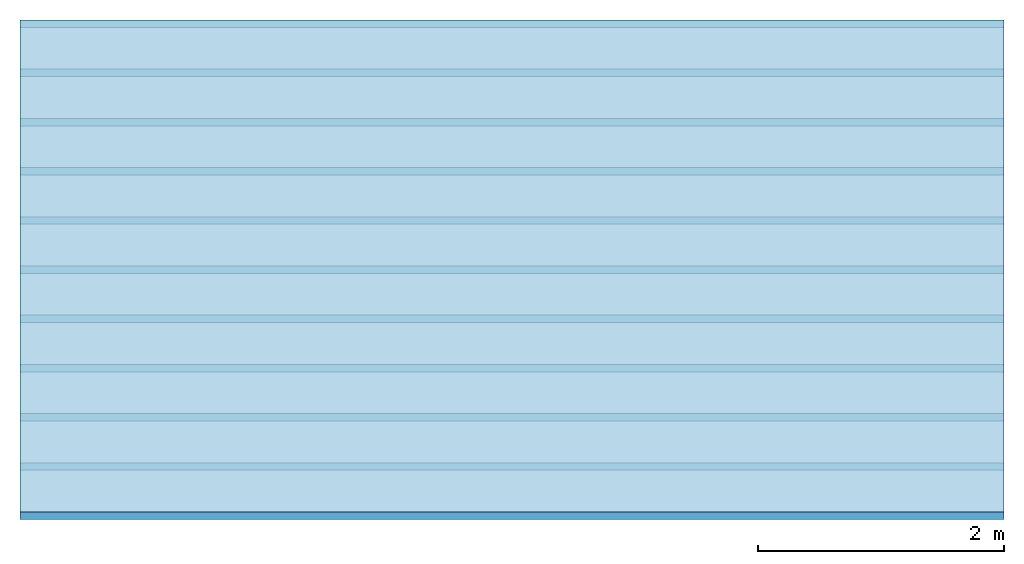
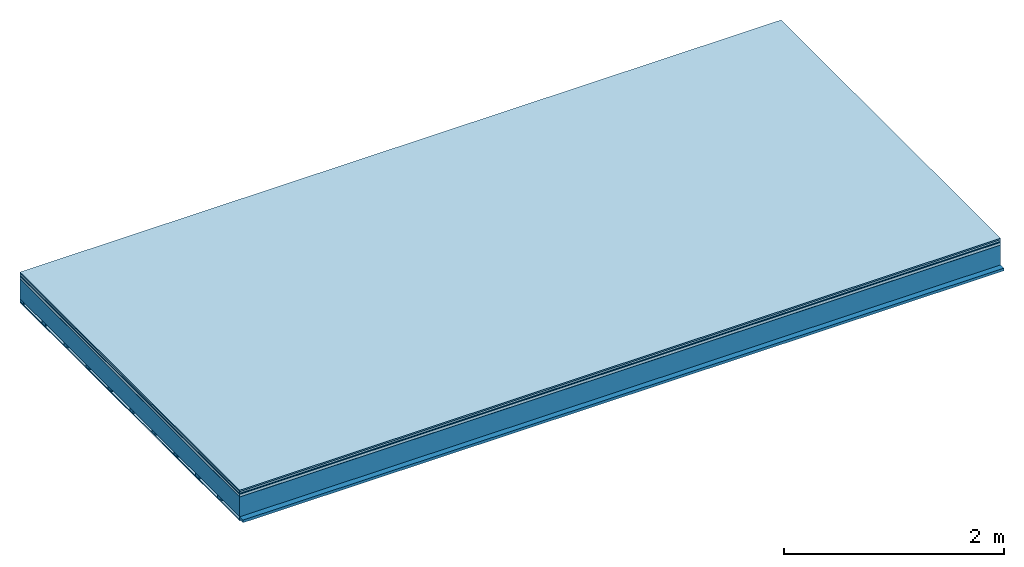
# One storey: 7 plates, 2 members, 1 element without a shape of its own.
"""IFC4 building model written with IfcOpenShell, lengths in metres."""

from ifc_helpers import new_model, si_unit, derived_unit, direction, frame, frame_2d, origin, origin_with_axes, place, context, project, spatial, rectangle, extrude, material, layer, layer_set, type_object, element, aggregate, save


model = new_model("IFC4")

# Units and contexts
plan_context = context("Plan", 3, precision=1e-05, world=origin(), true_north=direction((0.0, 1.0)))
model_context = context("Model", 3, precision=1e-05, world=origin(), true_north=direction((0.0, 1.0)))
ifc_project = project(units=[si_unit("LENGTHUNIT", "METRE"), derived_unit("SOUNDPRESSUREUNIT", [(si_unit("PRESSUREUNIT", "PASCAL", prefix="MICRO"), 0)]), si_unit("ENERGYUNIT", "JOULE", prefix="MEGA"), si_unit("MASSUNIT", "GRAM", prefix="KILO"), derived_unit("THERMALTRANSMITTANCEUNIT", [(si_unit("POWERUNIT", "WATT"), 1), (si_unit("AREAUNIT", "SQUARE_METRE"), -1), (si_unit("THERMODYNAMICTEMPERATUREUNIT", "KELVIN"), -1)]), derived_unit("AREADENSITYUNIT", [(si_unit("MASSUNIT", "GRAM", prefix="KILO"), 1), (si_unit("AREAUNIT", "SQUARE_METRE"), -1)]), derived_unit("USERDEFINED", [(si_unit("ENERGYUNIT", "JOULE", prefix="MEGA"), 1), (si_unit("AREAUNIT", "SQUARE_METRE"), -1)])], contexts=[plan_context, model_context])

# Site, building, storey
site = spatial("IfcSite", under=ifc_project)
building_placement = place(None, origin())
building = spatial("IfcBuilding", under=site, at=building_placement)
storey_placement = place(building_placement, origin())
storey = spatial("IfcBuildingStorey", under=building, at=storey_placement)

# Slab, members, plates
ifc_material_1 = material(Category="11.013")
ifc_layer_1 = layer(ifc_material_1, 0.015, Name="Flooring")
ifc_material_2 = material(Category="03.007")
ifc_layer_2 = layer(ifc_material_2, 0.02, Name="On-material")
ifc_material_3 = material(Name="Wood fiber generic product", Category="10.009")
ifc_layer_3 = layer(ifc_material_3, 0.01, Name="Impact sound insulation")
ifc_material_4 = material(Name="with broken")
ifc_layer_4 = layer(ifc_material_4, 0.03, Name="on Supporting structure")
ifc_material_5 = material(Name="protection", Category="09.007")
ifc_layer_5 = layer(ifc_material_5, 0.0005, Name="Sub-floor")
ifc_material_6 = material(Name="no composite action")
ifc_layer_6 = layer(ifc_material_6, 0.0, Name="Bond")
ifc_layer_7 = layer(None, 0.22, Name="Supporting structure")
ifc_material_7 = material(Name="of the art")
ifc_layer_8 = layer(ifc_material_7, 0.0, Name="Bond")
ifc_layer_9 = layer(None, 0.03, Name="Battens / profiles")
ifc_material_8 = material(Name="Plasterboard type A", Category="03.008")
ifc_layer_10 = layer(ifc_material_8, 0.0125, Name="Ceiling covering 1st layer")
ifc_material_9 = material(Category="04.001")
ifc_layer_11 = layer(ifc_material_9, 0.003, Name="Surface / treatment")
ifc_layer_set = layer_set([ifc_layer_1, ifc_layer_2, ifc_layer_3, ifc_layer_4, ifc_layer_5, ifc_layer_6, ifc_layer_7, ifc_layer_8, ifc_layer_9, ifc_layer_10, ifc_layer_11])
slab_type = type_object("IfcSlabType", Name="A2110", PredefinedType="NOTDEFINED", material=ifc_layer_set)
slab_placement = place(None, frame((0.0, 0.0, 0.0), z_axis=(0.0, 0.0, -1.0), x_axis=(1.0, 0.0, 0.0)))
slab = element("IfcSlab", 1, at=slab_placement, inside=storey, type_object=slab_type, material=ifc_layer_set, Name="Slab #1")
ifc_material_10 = material(Name="Solid timber panel")
member_1_placement = place(slab_placement, origin())
member_1 = element("IfcMember", 2, at=member_1_placement, material=ifc_material_10, Name="Supporting structure", context=plan_context, shape_type="SweptSolid", body=[
    extrude(rectangle(XDim=1.0, YDim=0.22, at=frame_2d((0.5, 0.11), x_axis=(1.0, 0.0))), frame((0.0, 4.0, 0.0755), z_axis=(0.0, -1.0, 0.0), x_axis=(1.0, 0.0, 0.0)), (0.0, 0.0, 1.0), 4.0),
    extrude(rectangle(XDim=1.0, YDim=0.22, at=frame_2d((0.5, 0.11), x_axis=(1.0, 0.0))), frame((1.0, 4.0, 0.0755), z_axis=(0.0, -1.0, 0.0), x_axis=(1.0, 0.0, 0.0)), (0.0, 0.0, 1.0), 4.0),
    extrude(rectangle(XDim=1.0, YDim=0.22, at=frame_2d((0.5, 0.11), x_axis=(1.0, 0.0))), frame((2.0, 4.0, 0.0755), z_axis=(0.0, -1.0, 0.0), x_axis=(1.0, 0.0, 0.0)), (0.0, 0.0, 1.0), 4.0),
    extrude(rectangle(XDim=1.0, YDim=0.22, at=frame_2d((0.5, 0.11), x_axis=(1.0, 0.0))), frame((3.0, 4.0, 0.0755), z_axis=(0.0, -1.0, 0.0), x_axis=(1.0, 0.0, 0.0)), (0.0, 0.0, 1.0), 4.0),
    extrude(rectangle(XDim=1.0, YDim=0.22, at=frame_2d((0.5, 0.11), x_axis=(1.0, 0.0))), frame((4.0, 4.0, 0.0755), z_axis=(0.0, -1.0, 0.0), x_axis=(1.0, 0.0, 0.0)), (0.0, 0.0, 1.0), 4.0),
    extrude(rectangle(XDim=1.0, YDim=0.22, at=frame_2d((0.5, 0.11), x_axis=(1.0, 0.0))), frame((5.0, 4.0, 0.0755), z_axis=(0.0, -1.0, 0.0), x_axis=(1.0, 0.0, 0.0)), (0.0, 0.0, 1.0), 4.0),
    extrude(rectangle(XDim=1.0, YDim=0.22, at=frame_2d((0.5, 0.11), x_axis=(1.0, 0.0))), frame((6.0, 4.0, 0.0755), z_axis=(0.0, -1.0, 0.0), x_axis=(1.0, 0.0, 0.0)), (0.0, 0.0, 1.0), 4.0),
    extrude(rectangle(XDim=1.0, YDim=0.22, at=frame_2d((0.5, 0.11), x_axis=(1.0, 0.0))), frame((7.0, 4.0, 0.0755), z_axis=(0.0, -1.0, 0.0), x_axis=(1.0, 0.0, 0.0)), (0.0, 0.0, 1.0), 4.0),
])
ifc_material_11 = material()
member_2_placement = place(slab_placement, origin())
member_2 = element("IfcMember", 3, at=member_2_placement, material=ifc_material_11, Name="Battens / profiles", context=plan_context, shape_type="SweptSolid", body=[
    extrude(rectangle(XDim=0.06, YDim=0.03, at=frame_2d((0.03, 0.015), x_axis=(1.0, 0.0))), frame((0.0, 0.0, 0.2955), z_axis=(1.0, 0.0, 0.0), x_axis=(0.0, 1.0, 0.0)), (0.0, 0.0, 1.0), 8.0),
    extrude(rectangle(XDim=0.06, YDim=0.03, at=frame_2d((0.03, 0.015), x_axis=(1.0, 0.0))), frame((0.0, 0.4, 0.2955), z_axis=(1.0, 0.0, 0.0), x_axis=(0.0, 1.0, 0.0)), (0.0, 0.0, 1.0), 8.0),
    extrude(rectangle(XDim=0.06, YDim=0.03, at=frame_2d((0.03, 0.015), x_axis=(1.0, 0.0))), frame((0.0, 0.8, 0.2955), z_axis=(1.0, 0.0, 0.0), x_axis=(0.0, 1.0, 0.0)), (0.0, 0.0, 1.0), 8.0),
    extrude(rectangle(XDim=0.06, YDim=0.03, at=frame_2d((0.03, 0.015), x_axis=(1.0, 0.0))), frame((0.0, 1.2, 0.2955), z_axis=(1.0, 0.0, 0.0), x_axis=(0.0, 1.0, 0.0)), (0.0, 0.0, 1.0), 8.0),
    extrude(rectangle(XDim=0.06, YDim=0.03, at=frame_2d((0.03, 0.015), x_axis=(1.0, 0.0))), frame((0.0, 1.6, 0.2955), z_axis=(1.0, 0.0, 0.0), x_axis=(0.0, 1.0, 0.0)), (0.0, 0.0, 1.0), 8.0),
    extrude(rectangle(XDim=0.06, YDim=0.03, at=frame_2d((0.03, 0.015), x_axis=(1.0, 0.0))), frame((0.0, 2.0, 0.2955), z_axis=(1.0, 0.0, 0.0), x_axis=(0.0, 1.0, 0.0)), (0.0, 0.0, 1.0), 8.0),
    extrude(rectangle(XDim=0.06, YDim=0.03, at=frame_2d((0.03, 0.015), x_axis=(1.0, 0.0))), frame((0.0, 2.4, 0.2955), z_axis=(1.0, 0.0, 0.0), x_axis=(0.0, 1.0, 0.0)), (0.0, 0.0, 1.0), 8.0),
    extrude(rectangle(XDim=0.06, YDim=0.03, at=frame_2d((0.03, 0.015), x_axis=(1.0, 0.0))), frame((0.0, 2.8, 0.2955), z_axis=(1.0, 0.0, 0.0), x_axis=(0.0, 1.0, 0.0)), (0.0, 0.0, 1.0), 8.0),
    extrude(rectangle(XDim=0.06, YDim=0.03, at=frame_2d((0.03, 0.015), x_axis=(1.0, 0.0))), frame((0.0, 3.2, 0.2955), z_axis=(1.0, 0.0, 0.0), x_axis=(0.0, 1.0, 0.0)), (0.0, 0.0, 1.0), 8.0),
    extrude(rectangle(XDim=0.06, YDim=0.03, at=frame_2d((0.03, 0.015), x_axis=(1.0, 0.0))), frame((0.0, 3.6, 0.2955), z_axis=(1.0, 0.0, 0.0), x_axis=(0.0, 1.0, 0.0)), (0.0, 0.0, 1.0), 8.0),
    extrude(rectangle(XDim=0.06, YDim=0.03, at=frame_2d((0.03, 0.015), x_axis=(1.0, 0.0))), frame((0.0, 4.0, 0.2955), z_axis=(1.0, 0.0, 0.0), x_axis=(0.0, 1.0, 0.0)), (0.0, 0.0, 1.0), 8.0),
])
plate_1_placement = place(slab_placement, origin())
plate_1 = element("IfcPlate", 4, at=plate_1_placement, material=ifc_material_1, Name="Flooring", context=plan_context, shape_type="SweptSolid", body=[
    extrude(rectangle(XDim=8.0, YDim=4.0, at=frame_2d((4.0, 2.0), x_axis=(1.0, 0.0))), origin_with_axes(), (0.0, 0.0, 1.0), 0.015),
])
plate_2_placement = place(slab_placement, origin())
plate_2 = element("IfcPlate", 5, at=plate_2_placement, material=ifc_material_2, Name="On-material", context=plan_context, shape_type="SweptSolid", body=[
    extrude(rectangle(XDim=8.0, YDim=4.0, at=frame_2d((4.0, 2.0), x_axis=(1.0, 0.0))), frame((0.0, 0.0, 0.015), z_axis=(0.0, 0.0, 1.0), x_axis=(1.0, 0.0, 0.0)), (0.0, 0.0, 1.0), 0.02),
])
plate_3_placement = place(slab_placement, origin())
plate_3 = element("IfcPlate", 6, at=plate_3_placement, material=ifc_material_3, Name="Impact sound insulation", context=plan_context, shape_type="SweptSolid", body=[
    extrude(rectangle(XDim=8.0, YDim=4.0, at=frame_2d((4.0, 2.0), x_axis=(1.0, 0.0))), frame((0.0, 0.0, 0.035), z_axis=(0.0, 0.0, 1.0), x_axis=(1.0, 0.0, 0.0)), (0.0, 0.0, 1.0), 0.01),
])
plate_4_placement = place(slab_placement, origin())
plate_4 = element("IfcPlate", 7, at=plate_4_placement, material=ifc_material_4, Name="on Supporting structure", context=plan_context, shape_type="SweptSolid", body=[
    extrude(rectangle(XDim=8.0, YDim=4.0, at=frame_2d((4.0, 2.0), x_axis=(1.0, 0.0))), frame((0.0, 0.0, 0.045), z_axis=(0.0, 0.0, 1.0), x_axis=(1.0, 0.0, 0.0)), (0.0, 0.0, 1.0), 0.03),
])
plate_5_placement = place(slab_placement, origin())
plate_5 = element("IfcPlate", 8, at=plate_5_placement, material=ifc_material_5, Name="Sub-floor", context=plan_context, shape_type="SweptSolid", body=[
    extrude(rectangle(XDim=8.0, YDim=4.0, at=frame_2d((4.0, 2.0), x_axis=(1.0, 0.0))), frame((0.0, 0.0, 0.075), z_axis=(0.0, 0.0, 1.0), x_axis=(1.0, 0.0, 0.0)), (0.0, 0.0, 1.0), 0.0005),
])
plate_6_placement = place(slab_placement, origin())
plate_6 = element("IfcPlate", 9, at=plate_6_placement, material=ifc_material_8, Name="Ceiling covering 1st layer", context=plan_context, shape_type="SweptSolid", body=[
    extrude(rectangle(XDim=8.0, YDim=4.0, at=frame_2d((4.0, 2.0), x_axis=(1.0, 0.0))), frame((0.0, 0.0, 0.3255), z_axis=(0.0, 0.0, 1.0), x_axis=(1.0, 0.0, 0.0)), (0.0, 0.0, 1.0), 0.0125),
])
plate_7_placement = place(slab_placement, origin())
plate_7 = element("IfcPlate", 10, at=plate_7_placement, material=ifc_material_9, Name="Surface / treatment", context=plan_context, shape_type="SweptSolid", body=[
    extrude(rectangle(XDim=8.0, YDim=4.0, at=frame_2d((4.0, 2.0), x_axis=(1.0, 0.0))), frame((0.0, 0.0, 0.338), z_axis=(0.0, 0.0, 1.0), x_axis=(1.0, 0.0, 0.0)), (0.0, 0.0, 1.0), 0.003),
])
aggregate(slab, [plate_1, plate_2, plate_3, plate_4, plate_5, member_1, member_2, plate_6, plate_7])

save(model, "model.ifc")
